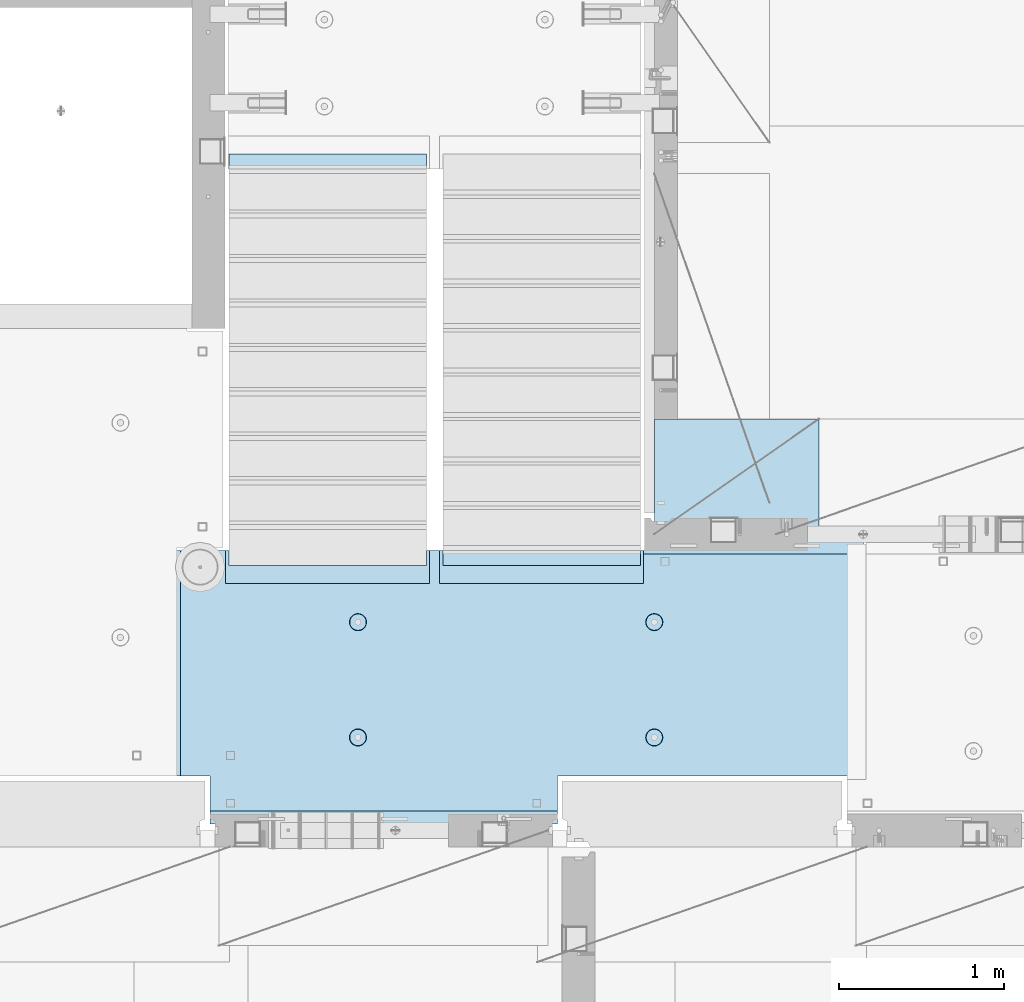
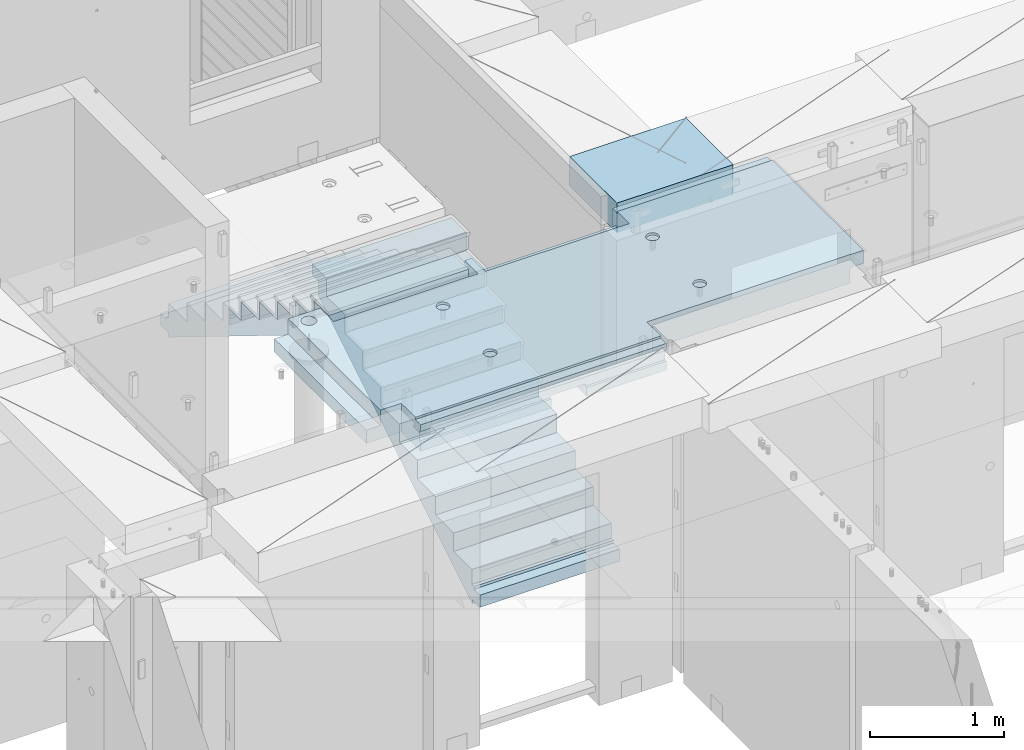
# One storey, part 208 of 350: 3 plates, 1 slab, 4 elements without a shape of their own.
"""IFC2X3 building model written with IfcOpenShell, lengths in millimetres."""

import ifcopenshell
import ifcopenshell.guid

model = None  # the IFC model being written
_history = None  # IfcOwnerHistory: only IFC2X3 demands one
_inside = {}  # id of a spatial element -> (the spatial element, [elements in it])
_under = {}  # id of a project, library or spatial element -> (it, [spatial elements below it])
_declared = {}  # id of a project -> (the project, [libraries it declares])
_typed = {}  # id of a type object -> (the type object, [elements of that type])
_made_of = {}  # id of a material, layer set ... -> (it, [elements and type objects made of it])


def new_model(schema):
    """Start an empty IFC model of exactly this schema.

    Asked for "IFC4X3", IfcOpenShell would pick the latest addendum, in which some entities
    have other attributes; the version numbers below select the first issue.
    IFC2X3 requires an IfcOwnerHistory on every rooted entity: one is made here for all.
    """
    global model, _history
    if schema == "IFC4X3":
        model = ifcopenshell.file(schema_version=(4, 3, 0, 0))
    else:
        model = ifcopenshell.file(schema=schema)
    _inside.clear()
    _under.clear()
    _declared.clear()
    _typed.clear()
    _made_of.clear()
    _history = None
    if model.schema == "IFC2X3":
        org = make("IfcOrganization", Name="unknown")
        user = make(
            "IfcPersonAndOrganization",
            ThePerson=make("IfcPerson", FamilyName="unknown"),
            TheOrganization=org,
        )
        app = make(
            "IfcApplication",
            ApplicationDeveloper=org,
            Version="unknown",
            ApplicationFullName="unknown",
            ApplicationIdentifier="unknown",
        )
        _history = make(
            "IfcOwnerHistory",
            OwningUser=user,
            OwningApplication=app,
            ChangeAction="ADDED",
            CreationDate=0,
        )
    return model


def make(cls, **values):
    """One entity of the class cls with the attributes given. An attribute that is None is left unset."""
    return model.create_entity(
        cls, **{name: value for name, value in values.items() if value is not None}
    )


def rooted(cls, **values):
    """An entity with a GlobalId (a new one), such as an element, a storey or a relation."""
    return make(cls, GlobalId=ifcopenshell.guid.new(), OwnerHistory=_history, **values)


def si_unit(unit_type, name, prefix=None):
    """IfcSIUnit, for example si_unit("LENGTHUNIT", "METRE", prefix="MILLI")."""
    return make("IfcSIUnit", UnitType=unit_type, Prefix=prefix, Name=name)


def assignment(units):
    """IfcUnitAssignment: the units of a project."""
    return None if units is None else make("IfcUnitAssignment", Units=units)


def point(xyz):
    """IfcCartesianPoint."""
    return None if xyz is None else make("IfcCartesianPoint", Coordinates=xyz)


def direction(xyz):
    """IfcDirection."""
    return None if xyz is None else make("IfcDirection", DirectionRatios=xyz)


def frame(location, z_axis=None, x_axis=None):
    """IfcAxis2Placement3D, a coordinate frame: its origin and axes. An axis left out is left unset."""
    return make(
        "IfcAxis2Placement3D",
        Location=point(location),
        Axis=direction(z_axis),
        RefDirection=direction(x_axis),
    )


def origin_with_axes():
    """The frame at (0, 0, 0) with the z axis (0, 0, 1) and the x axis (1, 0, 0) written out."""
    return frame((0.0, 0.0, 0.0), z_axis=(0.0, 0.0, 1.0), x_axis=(1.0, 0.0, 0.0))


def place(relative_to, where):
    """IfcLocalPlacement: puts the frame where relative to a parent placement (None: the world)."""
    return make(
        "IfcLocalPlacement", PlacementRelTo=relative_to, RelativePlacement=where
    )


def context(
    kind, dimensions, precision=None, world=None, true_north=None, identifier=None
):
    """IfcGeometricRepresentationContext, for example the 3D "Model" context."""
    return make(
        "IfcGeometricRepresentationContext",
        ContextIdentifier=identifier,
        ContextType=kind,
        CoordinateSpaceDimension=dimensions,
        Precision=precision,
        WorldCoordinateSystem=world,
        TrueNorth=true_north,
    )


def subcontext(parent, identifier, kind, view, scale=None):
    """IfcGeometricRepresentationSubContext, for example "Body" below "Model"."""
    return make(
        "IfcGeometricRepresentationSubContext",
        ContextIdentifier=identifier,
        ContextType=kind,
        ParentContext=parent,
        TargetScale=scale,
        TargetView=view,
    )


def project(units=None, contexts=None):
    """IfcProject with its units and contexts."""
    return rooted(
        "IfcProject",
        Name="project",
        RepresentationContexts=contexts,
        UnitsInContext=assignment(units),
    )


def spatial(cls, under=None, at=None, **own):
    """A site, building, storey or space (cls), placed at a placement, below another one or the project."""
    s = rooted(cls, ObjectPlacement=at, **own)
    if under is not None:
        _under.setdefault(under.id(), (under, []))[1].append(s)
    return s


def faces_of(points, faces, orient=None, outer=None):
    """IfcFace entities. A face is a list of loops; a loop is a list of indices into points, from 0.

    orient and outer hold one flag for each loop. By default every Orientation is true, the
    first loop of a face is its IfcFaceOuterBound and the others are IfcFaceBound.
    """
    made = []
    for i, loops in enumerate(faces):
        bounds = []
        for j, loop in enumerate(loops):
            is_outer = j == 0 if outer is None else outer[i][j]
            bounds.append(
                make(
                    "IfcFaceOuterBound" if is_outer else "IfcFaceBound",
                    Bound=make("IfcPolyLoop", Polygon=[points[k] for k in loop]),
                    Orientation=True if orient is None else orient[i][j],
                )
            )
        made.append(make("IfcFace", Bounds=bounds))
    return made


def faceted_brep(points, faces, orient=None, outer=None, voids=None):
    """IfcFacetedBrep: a solid bounded by flat faces; with voids (closed shells), ...WithVoids."""
    shared = [point(p) for p in points]
    hull = make("IfcClosedShell", CfsFaces=faces_of(shared, faces, orient, outer))
    if voids is None:
        return make("IfcFacetedBrep", Outer=hull)
    return make(
        "IfcFacetedBrepWithVoids",
        Outer=hull,
        Voids=[
            make(cls, CfsFaces=faces_of(shared, fs, o, b)) for cls, fs, o, b in voids
        ],
    )


def shape(context_of_items, identifier, shape_type, items):
    """IfcShapeRepresentation: the items that make up one representation, for example the "Body"."""
    return make(
        "IfcShapeRepresentation",
        ContextOfItems=context_of_items,
        RepresentationIdentifier=identifier,
        RepresentationType=shape_type,
        Items=items,
    )


def material(Name=None, Category=None):
    """IfcMaterial."""
    return make("IfcMaterial", Name=Name, Category=Category)


def made_of(thing, what):
    """Note that an element or type object is made of a material, layer set ...; save() writes the relation."""
    if what is not None:
        _made_of.setdefault(what.id(), (what, []))[1].append(thing)
    return thing


def type_object(cls, material=None, **own):
    """A type object (cls), such as IfcWallType, which elements share."""
    return made_of(rooted(cls, **own), material)


def element(
    cls,
    number,
    at=None,
    inside=None,
    cuts=None,
    type_object=None,
    material=None,
    context=None,
    identifier="Body",
    shape_type=None,
    held_by="IfcProductDefinitionShape",
    body=None,
    shapes=None,
    **own,
):
    """One element of the class cls, such as IfcWall. Its Tag is "e" and its number.

    at: its placement. inside: the storey or other place that contains it. cuts: it is an
    opening in that element (IfcRelVoidsElement). A single representation is given by context,
    identifier, shape_type and body (its items); several are given by shapes. held_by: the class
    of the entity that holds the representations. save() writes the other relations.
    """
    e = rooted(cls, Tag="e%d" % number, ObjectPlacement=at, **own)
    if body is not None:
        shapes = [shape(context, identifier, shape_type, body)]
    if shapes is not None:
        e.Representation = make(held_by, Representations=shapes)
    if inside is not None:
        _inside.setdefault(inside.id(), (inside, []))[1].append(e)
    if cuts is not None:
        rooted(
            "IfcRelVoidsElement", RelatingBuildingElement=cuts, RelatedOpeningElement=e
        )
    if type_object is not None:
        _typed.setdefault(type_object.id(), (type_object, []))[1].append(e)
    return made_of(e, material)


def aggregate(whole, parts):
    """IfcRelAggregates: a whole, such as a stair, and the parts it consists of."""
    return rooted("IfcRelAggregates", RelatingObject=whole, RelatedObjects=parts)


def save(model, path):
    """Write the relations noted so far, then the file.

    IfcRelAggregates (storeys below a building ...), IfcRelContainedInSpatialStructure (elements
    in a storey), IfcRelDefinesByType, IfcRelAssociatesMaterial and IfcRelDeclares: one each for
    every whole, place, type object, material and project.
    """
    for whole, parts in _under.values():
        aggregate(whole, parts)
    for where, things in _inside.values():
        rooted(
            "IfcRelContainedInSpatialStructure",
            RelatedElements=things,
            RelatingStructure=where,
        )
    for kind, things in _typed.values():
        rooted("IfcRelDefinesByType", RelatedObjects=things, RelatingType=kind)
    for what, things in _made_of.values():
        rooted("IfcRelAssociatesMaterial", RelatedObjects=things, RelatingMaterial=what)
    for by, libraries in _declared.values():
        rooted("IfcRelDeclares", RelatingContext=by, RelatedDefinitions=libraries)
    model.write(path)


model = new_model("IFC2X3")

# Units and contexts
model_context = context("Model", 3, precision=1e-05, world=origin_with_axes())
body_context = subcontext(model_context, "Body", "Model", "MODEL_VIEW")
ifc_project = project(units=[si_unit("LENGTHUNIT", "METRE", prefix="MILLI"), si_unit("AREAUNIT", "SQUARE_METRE"), si_unit("VOLUMEUNIT", "CUBIC_METRE"), si_unit("MASSUNIT", "GRAM", prefix="KILO"), si_unit("TIMEUNIT", "SECOND"), si_unit("PLANEANGLEUNIT", "RADIAN"), si_unit("SOLIDANGLEUNIT", "STERADIAN"), si_unit("THERMODYNAMICTEMPERATUREUNIT", "DEGREE_CELSIUS"), si_unit("LUMINOUSINTENSITYUNIT", "LUMEN")], contexts=[model_context])

# Site, building, storey
site_placement = place(None, origin_with_axes())
site = spatial("IfcSite", under=ifc_project, at=site_placement, CompositionType="ELEMENT")
building_placement = place(site_placement, origin_with_axes())
building = spatial("IfcBuilding", under=site, at=building_placement, CompositionType="ELEMENT")
storey_placement = place(building_placement, origin_with_axes())
storey = spatial("IfcBuildingStorey", under=building, at=storey_placement, Name="2", CompositionType="ELEMENT", Elevation=0.0)

# Assembly, slab
assembly_1_placement = place(storey_placement, origin_with_axes())
assembly_1 = element("IfcElementAssembly", 1, at=assembly_1_placement, inside=storey, AssemblyPlace="NOTDEFINED", PredefinedType="REINFORCEMENT_UNIT")
ifc_material_1 = material(Name="CONCRETE/C25/30")
slab_type = type_object("IfcSlabType", PredefinedType="NOTDEFINED")
slab_placement = place(assembly_1_placement, frame((23540.0159390845, 15510.0026483125, 87620.0), z_axis=(-0.999999999997437, -2.26400000064461e-06, 0.0), x_axis=(-2.2639999995273e-06, 0.999999999997437, 0.0)))
slab = element("IfcSlab", 2, at=slab_placement, type_object=slab_type, material=ifc_material_1, PredefinedType="FLOOR", context=body_context, shape_type="Brep", body=[
    faceted_brep([(-269.991394356101, 30.0, 2845.00213671412), (-79.9935682977648, 30.0, 2845.00213671301), (-79.9942474988402, 30.0, 2545.001661275), (-269.991475956112, 30.0, 2545.00209142873), (-79.9935682977648, 130.0, 2845.00213671301), (-269.991394356102, 50.0011356208415, 2845.00213671412), (-289.993566176285, 50.0011356208415, 2845.00213671423), (-289.993566176285, 130.0, 2845.00213671423), (-79.9942474988402, 130.0, 2545.001661275), (-289.994243058944, 130.0, 2545.00213671499), (-289.994243058944, 50.0011356208415, 2545.00213671499), (-269.991475956114, 50.0011356208415, 2545.00209142873), (250.667816023648, -110.0, 1223.00869116667), (264.606228919523, -110.0, 1230.11066726268), (275.667816023648, -110.0, 1241.1722543668), (282.76979211966, -110.0, 1255.11066726268), (285.216966304903, -110.0, 1270.56151698143), (282.769792119658, -110.0, 1286.01236670018), (275.667816023648, -110.0, 1299.95077959605), (264.606228919525, -110.0, 1311.01236670018), (250.667816023648, -110.0, 1318.11434279619), (235.216966304901, -110.0, 1320.56151698143), (219.766116586154, -110.0, 1318.11434279619), (205.827703690276, -110.0, 1311.01236670018), (194.766116586154, -110.0, 1299.95077959605), (187.664140490142, -110.0, 1286.01236670018), (185.216966304899, -110.0, 1270.56151698143), (187.664140490144, -110.0, 1255.11066726268), (194.766116586154, -110.0, 1241.1722543668), (205.827703690276, -110.0, 1230.11066726268), (219.766116586154, -110.0, 1223.00869116667), (235.216966304901, -110.0, 1220.56151698143), (251.370127374501, -130.0, 1220.84719908418), (235.216966304901, -130.0, 1218.2887897087), (265.942104492917, -130.0, 1228.27199227546), (277.506491010863, -130.0, 1239.83637879341), (284.931284202146, -130.0, 1254.40835591183), (287.489693577627, -130.0, 1270.56151698143), (284.931284202146, -130.0, 1286.71467805103), (277.506491010861, -130.0, 1301.28665516945), (265.942104492917, -130.0, 1312.85104168739), (251.370127374501, -130.0, 1320.27583487867), (235.216966304901, -130.0, 1322.83424425416), (219.063805235301, -130.0, 1320.27583487867), (204.491828116883, -130.0, 1312.85104168739), (192.927441598938, -130.0, 1301.28665516945), (185.502648407655, -130.0, 1286.71467805103), (182.944239032175, -130.0, 1270.56151698143), (185.502648407655, -130.0, 1254.40835591183), (192.92744159894, -130.0, 1239.83637879341), (204.491828116883, -130.0, 1228.27199227546), (219.063805235301, -130.0, 1220.84719908418), (1370.00988769532, 9.99999999994179, 4270.0029296875), (0.00703133410206647, 9.99999999994179, 4270.00341796875), (0.00594789032584231, 9.99999999994179, 4150.00335886026), (1370.00950450419, 9.99999999994179, 4150.0022190173), (1370.00988769532, 130.0, 4270.0029296875), (0.00703133410206647, 130.0, 4270.00341796875), (-289.995788574217, 50.0011356208415, 1860.01696777343), (-269.99166227209, 50.0011356208415, 1860.01689198933), (-289.995788574217, 130.0, 1860.01696777343), (1410.00403637765, -10.0000000000582, 115.00218916441), (-0.000334584017764428, -10.0000000000582, 115.003668258996), (-0.000334584015945438, 130.0, 115.003668258996), (1430.00436377147, 130.0, 115.002168181909), (1430.00283514406, 50.0011356437899, 115.002168184747), (1410.00403637764, 50.0011356208415, 115.002189163421), (1430.00659179688, 130.0, 1330.01220703125), (1370.00036621094, 130.0, 1330.01281738281), (1370.00036621094, -110.000000000073, 1330.01281738281), (1430.00659179688, -110.000000000073, 1330.01220703125), (1430.00656714066, -110.000000000073, 1.33804860524833e-08), (1350.00656713971, -110.000000000073, -1.09139364212751e-10), (1350.00656713971, -130.0, -9.31322574615479e-10), (0.0, -130.0, -3.63797880709171e-12), (0.0, -10.0, 0.0), (1410.00416932017, -10.0000000000582, 1.69893610291183e-09), (1410.00416932017, -49.9988643791585, 5.89352566748858e-10), (1430.00416932019, -49.9988643791585, 2.83398549072444e-09), (1430.00277003324, 50.0011356208415, 1270.01537795496), (1430.00277003324, -49.9988643791585, 1270.01537795496), (1410.00277003325, 50.0011356208415, 1270.01535591496), (1410.00277003325, -49.9988643791585, 1270.01535591496), (-0.00148380931932479, -130.0, 510.016937255856), (-0.00148380931932479, 130.0, 510.016937255856), (0.00156440050341189, -130.0, 1860.01586914062), (0.00156440050341189, 130.0, 1860.01586914062), (-209.991713751984, -130.000000000058, 1860.01666468411), (-209.996345203012, -130.0, 3970.01713194715), (-209.996345203012, -110.000000000058, 3970.01713194715), (-209.991713751984, -110.000000000058, 1860.01666468411), (-289.991027832028, -110.000000000058, 3970.01733398437), (-289.995788574217, -110.000000000058, 1860.01696777343), (-289.991027832028, -49.9988643791585, 3970.01733398437), (-289.995788574217, -49.9988643791585, 1860.01696777343), (-269.99166227209, -49.9988643791585, 1860.01689198933), (-289.991027832028, 50.0011356208415, 3970.01733398437), (-289.991027832028, 130.0, 3970.01733398437), (-269.991088351981, 50.0011356208415, 3970.01728347186), (-269.991088351981, -49.9988643791585, 3970.01728347186), (0.00432284502676339, -130.0, 3970.0166015625), (0.00432284502676339, 130.0, 3970.0166015625), (0.00594789032584231, -130.0, 4150.00335886026), (1370.00950450419, -130.000000000058, 4150.0022190173), (1370.00860847198, 9.99639270307671, 3875.01157736929), (1170.00318277859, 9.99639270307671, 3875.01203018158), (1170.00037541444, 9.99639270307671, 2635.01019913007), (1370.00459258838, 9.99639270307671, 2635.00974632052), (1370.00860847197, -130.000000000058, 3875.01157736929), (1170.00318277859, -130.000000000029, 3875.01203018158), (1170.00037541444, -130.000000000029, 2635.01019913007), (1370.00459258838, -130.000000000029, 2635.00974632052), (1370.00439827764, -130.000000000029, 2575.01157737549), (1170.00023957859, -130.000000000029, 2575.01203018491), (1170.00023957859, 9.99639270307671, 2575.01203018491), (1370.00439827764, 9.99639270307671, 2575.01157737549), (1169.99743221444, -130.000000000029, 1335.0101991334), (1169.99743221444, 9.99639270307671, 1335.0101991334), (1370.00038239405, 9.99639270307671, 1335.00974632672), (1370.00038239405, -110.000000000073, 1335.00974632672), (1350.00004294686, -110.000000000073, 1335.00979160748), (1350.00004294686, -130.000000000073, 1335.00979160748), (920.332855772751, -110.0, 1318.11282667454), (906.394410719273, -110.0, 1311.01091369173), (895.332773528397, -110.0, 1299.94937667459), (888.230734319324, -110.0, 1286.01099593661), (885.78349017266, -110.0, 1270.56015729882), (888.230594396427, -110.0, 1255.10929649942), (895.332507379233, -110.0, 1241.17085144594), (906.394044396377, -110.0, 1230.10921425507), (920.332425134358, -110.0, 1223.00717504599), (935.783263772144, -110.0, 1220.55993089933), (951.234124571543, -110.0, 1223.0070351231), (965.172569625021, -110.0, 1230.10894810591), (976.234206815898, -110.0, 1241.17048512305), (983.33624602497, -110.0, 1255.10886586103), (985.783490171634, -110.0, 1270.55970449882), (983.336385947867, -110.0, 1286.01056529821), (976.234472965061, -110.0, 1299.94901035169), (965.172935947918, -110.0, 1311.01064754257), (951.234555209936, -110.0, 1318.11268675164), (935.783716572147, -110.0, 1320.5599308983), (951.936426135147, -130.0, 1220.84553986057), (935.783253481237, -130.0, 1218.28720362663), (966.508436872882, -130.0, 1228.27026706986), (978.072875754253, -130.0, 1239.83460122415), (985.497734927369, -130.0, 1254.40654472295), (988.05621744434, -130.0, 1270.55969420791), (985.497881210395, -130.0, 1286.71286686182), (978.073154001104, -130.0, 1301.28487759955), (966.508819846818, -130.0, 1312.84931648092), (951.936876348012, -130.0, 1320.27417565404), (935.783726863054, -130.0, 1322.83265817101), (919.630554209147, -130.0, 1320.27432193707), (905.058543471412, -130.0, 1312.84959472777), (893.494104590041, -130.0, 1301.28526057349), (886.069245416922, -130.0, 1286.71331707469), (883.510762899954, -130.0, 1270.56016758973), (886.069099133892, -130.0, 1254.40699493582), (893.49382634319, -130.0, 1239.83498419809), (905.058160497476, -130.0, 1228.27054531671), (919.630103996282, -130.0, 1220.84568614359), (920.336931380272, -110.0, 3118.29282666992), (906.398486326791, -110.0, 3111.19091368712), (895.336849135918, -110.0, 3100.12937666997), (888.234809926846, -110.0, 3086.19099593199), (885.787565780181, -110.0, 3070.7401572942), (888.234670003949, -110.0, 3055.28929649481), (895.336582986754, -110.0, 3041.35085144133), (906.398120003898, -110.0, 3030.28921425045), (920.33650074188, -110.0, 3023.18717504138), (935.787339379665, -110.0, 3020.73993089472), (951.238200179065, -110.0, 3023.18703511849), (965.176645232543, -110.0, 3030.28894810129), (976.238282423419, -110.0, 3041.35048511844), (983.340321632491, -110.0, 3055.28886585642), (985.787565779156, -110.0, 3070.7397044942), (983.340461555388, -110.0, 3086.1905652936), (976.238548572583, -110.0, 3100.12901034708), (965.177011555439, -110.0, 3111.19064753796), (951.238630817454, -110.0, 3118.29268674703), (935.787792179664, -110.0, 3120.73993089369), (951.940501742669, -130.000000000015, 3021.02553985595), (935.787329088758, -130.000000000015, 3018.46720362201), (966.512512480404, -130.000000000015, 3028.45026706525), (978.076951361778, -130.000000000015, 3040.01460121954), (985.50181053489, -130.000000000015, 3054.58654471834), (988.060293051862, -130.000000000015, 3070.73969420329), (985.501956817916, -130.000000000015, 3086.89286685721), (978.077229608625, -130.000000000015, 3101.46487759494), (966.51289545434, -130.000000000015, 3113.02931647631), (951.940951955534, -130.000000000015, 3120.45417564943), (935.787802470575, -130.000000000015, 3123.01265816639), (919.634629816665, -130.000000000015, 3120.45432193246), (905.062619078933, -130.000000000015, 3113.02959472316), (893.498180197559, -130.000000000015, 3101.46526056888), (886.07332102444, -130.000000000015, 3086.89331707007), (883.514838507475, -130.000000000015, 3070.74016758511), (886.073174741414, -130.000000000015, 3054.5869949312), (893.497901950712, -130.000000000015, 3040.01498419347), (905.062236104997, -130.000000000015, 3028.4505453121), (919.634179603803, -130.000000000015, 3021.02568613898), (250.671891631169, -110.0, 3023.18869116206), (264.610304527045, -110.0, 3030.29066725807), (275.671891631167, -110.0, 3041.35225436219), (282.773867727179, -110.0, 3055.29066725806), (285.221041912424, -110.0, 3070.74151697681), (282.773867727179, -110.0, 3086.19236669556), (275.671891631169, -110.0, 3100.13077959144), (264.610304527047, -110.0, 3111.19236669556), (250.671891631169, -110.0, 3118.29434279157), (235.221041912422, -110.0, 3120.74151697681), (219.770192193675, -110.0, 3118.29434279157), (205.831779297798, -110.0, 3111.19236669556), (194.770192193675, -110.0, 3100.13077959144), (187.668216097663, -110.0, 3086.19236669556), (185.22104191242, -110.0, 3070.74151697681), (187.668216097663, -110.0, 3055.29066725806), (194.770192193673, -110.0, 3041.35225436219), (205.831779297798, -110.0, 3030.29066725807), (219.770192193673, -110.0, 3023.18869116206), (235.221041912422, -110.0, 3020.74151697681), (251.374202982022, -130.0, 3021.02719907957), (235.221041912422, -130.0, 3018.46878970409), (265.946180100438, -130.0, 3028.45199227085), (277.510566618384, -130.0, 3040.0163787888), (284.935359809668, -130.0, 3054.58835590722), (287.493769185148, -130.0, 3070.74151697681), (284.935359809668, -130.0, 3086.89467804641), (277.510566618383, -130.0, 3101.46665516483), (265.946180100438, -130.0, 3113.03104168278), (251.374202982022, -130.0, 3120.45583487406), (235.22104191242, -130.0, 3123.01424424954), (219.067880842822, -130.0, 3120.45583487406), (204.495903724404, -130.0, 3113.03104168278), (192.93151720646, -130.0, 3101.46665516483), (185.506724015177, -130.0, 3086.89467804641), (182.948314639694, -130.0, 3070.74151697681), (185.506724015177, -130.0, 3054.58835590722), (192.93151720646, -130.0, 3040.0163787888), (204.495903724404, -130.0, 3028.45199227085), (219.06788084282, -130.0, 3021.02719907957), (1234.74413944682, -130.000000000029, 3981.4733287671), (1221.47026497402, -130.000000000029, 3994.74726334413), (1212.94793152671, -130.000000000029, 4011.47337811379), (1210.0113644813, -130.000000000029, 4030.01440442472), (1212.94801548044, -130.000000000029, 4048.55541743869), (1221.47042466352, -130.000000000029, 4065.28149361904), (1234.74435924055, -130.000000000029, 4078.55536809184), (1251.47047401021, -130.000000000029, 4087.07770153915), (1270.01150032114, -130.000000000029, 4090.01426858456), (1288.55251333511, -130.000000000029, 4087.07761758541), (1305.27858951547, -130.000000000029, 4078.55520840234), (1318.55246398826, -130.000000000029, 4065.28127382531), (1327.07479743557, -130.000000000029, 4048.55515905565), (1330.01136448099, -130.000000000029, 4030.01413274472), (1327.07471348184, -130.000000000029, 4011.47311973075), (1318.55230429877, -130.000000000029, 3994.74704355039), (1305.27836972173, -130.000000000029, 3981.4731690776), (1288.55225495208, -130.000000000029, 3972.95083563029), (1270.01122864114, -130.000000000029, 3970.01426858487), (1251.47021562717, -130.000000000029, 3972.95091958403), (1305.27836972173, 130.0, 3981.4731690776), (1288.55225495208, 130.0, 3972.95083563029), (1318.55230429877, 130.0, 3994.74704355039), (1327.07471348184, 130.0, 4011.47311973075), (1330.01136448099, 130.0, 4030.01413274472), (1327.07479743557, 130.0, 4048.55515905565), (1318.55246398826, 130.0, 4065.28127382531), (1305.27858951547, 130.0, 4078.55520840234), (1288.55251333511, 130.0, 4087.07761758541), (1270.01150032114, 130.0, 4090.01426858456), (1251.47047401021, 130.0, 4087.07770153915), (1234.74435924055, 130.0, 4078.55536809184), (1221.47042466352, 130.0, 4065.28149361904), (1212.94801548044, 130.0, 4048.55541743869), (1210.0113644813, 130.0, 4030.01440442472), (1212.94793152671, 130.0, 4011.47337811379), (1221.47026497402, 130.0, 3994.74726334413), (1234.74413944682, 130.0, 3981.4733287671), (1251.47021562717, 130.0, 3972.95091958403), (1270.01122864114, 130.0, 3970.01426858487)], [[[0, 1, 2, 3]], [[4, 1, 0, 5, 6, 7]], [[8, 2, 1, 4]], [[9, 10, 11, 3, 2, 8]], [[12, 13, 14, 15, 16, 17, 18, 19, 20, 21, 22, 23, 24, 25, 26, 27, 28, 29, 30, 31]], [[32, 12, 31, 33]], [[34, 13, 12, 32]], [[35, 14, 13, 34]], [[36, 15, 14, 35]], [[37, 16, 15, 36]], [[38, 17, 16, 37]], [[39, 18, 17, 38]], [[40, 19, 18, 39]], [[41, 20, 19, 40]], [[42, 21, 20, 41]], [[43, 22, 21, 42]], [[44, 23, 22, 43]], [[45, 24, 23, 44]], [[46, 25, 24, 45]], [[47, 26, 25, 46]], [[48, 27, 26, 47]], [[49, 28, 27, 48]], [[50, 29, 28, 49]], [[51, 30, 29, 50]], [[33, 31, 30, 51]], [[52, 53, 54, 55]], [[56, 57, 53, 52]], [[58, 59, 11, 10]], [[60, 58, 10, 9]], [[61, 62, 63, 64, 65, 66]], [[67, 68, 69, 70]], [[71, 72, 73, 74, 75, 76, 77, 78]], [[79, 65, 64, 67, 70, 71, 78, 80]], [[65, 79, 81, 66]], [[80, 82, 81, 79]], [[78, 77, 82, 80]], [[76, 61, 66, 81, 82, 77]], [[75, 62, 61, 76]], [[74, 83, 84, 63, 62, 75]], [[83, 85, 86, 84]], [[87, 88, 89, 90]], [[90, 89, 91, 92]], [[92, 91, 93, 94]], [[58, 60, 86, 85, 87, 90, 92, 94, 95, 59]], [[96, 97, 7, 6]], [[98, 96, 6, 5]], [[59, 95, 99, 98, 5, 0, 3, 11]], [[94, 93, 99, 95]], [[91, 89, 88, 100, 101, 97, 96, 98, 99, 93]], [[53, 57, 101, 100, 102, 54]], [[103, 55, 54, 102]], [[104, 105, 106, 107]], [[108, 109, 105, 104]], [[110, 106, 105, 109]], [[111, 107, 106, 110]], [[112, 113, 114, 115]], [[116, 117, 114, 113]], [[115, 114, 117, 118]], [[69, 68, 56, 52, 55, 103, 108, 104, 107, 111, 112, 115, 118, 119]], [[72, 71, 70, 69, 119, 120]], [[73, 72, 120, 121]], [[119, 118, 117, 116, 121, 120]], [[122, 123, 124, 125, 126, 127, 128, 129, 130, 131, 132, 133, 134, 135, 136, 137, 138, 139, 140, 141]], [[142, 132, 131, 143]], [[144, 133, 132, 142]], [[145, 134, 133, 144]], [[146, 135, 134, 145]], [[147, 136, 135, 146]], [[148, 137, 136, 147]], [[149, 138, 137, 148]], [[150, 139, 138, 149]], [[151, 140, 139, 150]], [[152, 141, 140, 151]], [[153, 122, 141, 152]], [[154, 123, 122, 153]], [[155, 124, 123, 154]], [[156, 125, 124, 155]], [[157, 126, 125, 156]], [[158, 127, 126, 157]], [[159, 128, 127, 158]], [[160, 129, 128, 159]], [[161, 130, 129, 160]], [[143, 131, 130, 161]], [[162, 163, 164, 165, 166, 167, 168, 169, 170, 171, 172, 173, 174, 175, 176, 177, 178, 179, 180, 181]], [[182, 172, 171, 183]], [[184, 173, 172, 182]], [[185, 174, 173, 184]], [[186, 175, 174, 185]], [[187, 176, 175, 186]], [[188, 177, 176, 187]], [[189, 178, 177, 188]], [[190, 179, 178, 189]], [[191, 180, 179, 190]], [[192, 181, 180, 191]], [[193, 162, 181, 192]], [[194, 163, 162, 193]], [[195, 164, 163, 194]], [[196, 165, 164, 195]], [[197, 166, 165, 196]], [[198, 167, 166, 197]], [[199, 168, 167, 198]], [[200, 169, 168, 199]], [[201, 170, 169, 200]], [[183, 171, 170, 201]], [[202, 203, 204, 205, 206, 207, 208, 209, 210, 211, 212, 213, 214, 215, 216, 217, 218, 219, 220, 221]], [[222, 202, 221, 223]], [[224, 203, 202, 222]], [[225, 204, 203, 224]], [[226, 205, 204, 225]], [[227, 206, 205, 226]], [[228, 207, 206, 227]], [[229, 208, 207, 228]], [[230, 209, 208, 229]], [[231, 210, 209, 230]], [[232, 211, 210, 231]], [[233, 212, 211, 232]], [[234, 213, 212, 233]], [[235, 214, 213, 234]], [[236, 215, 214, 235]], [[237, 216, 215, 236]], [[238, 217, 216, 237]], [[239, 218, 217, 238]], [[240, 219, 218, 239]], [[241, 220, 219, 240]], [[223, 221, 220, 241]], [[113, 112, 111, 110, 109, 108, 103, 102, 100, 88, 87, 85, 83, 74, 73, 121, 116], [240, 239, 238, 237, 236, 235, 234, 233, 232, 231, 230, 229, 228, 227, 226, 225, 224, 222, 223, 241], [200, 199, 198, 197, 196, 195, 194, 193, 192, 191, 190, 189, 188, 187, 186, 185, 184, 182, 183, 201], [160, 159, 158, 157, 156, 155, 154, 153, 152, 151, 150, 149, 148, 147, 146, 145, 144, 142, 143, 161], [50, 49, 48, 47, 46, 45, 44, 43, 42, 41, 40, 39, 38, 37, 36, 35, 34, 32, 33, 51], [242, 243, 244, 245, 246, 247, 248, 249, 250, 251, 252, 253, 254, 255, 256, 257, 258, 259, 260, 261]], [[258, 262, 263, 259]], [[257, 264, 262, 258]], [[256, 265, 264, 257]], [[255, 266, 265, 256]], [[254, 267, 266, 255]], [[253, 268, 267, 254]], [[252, 269, 268, 253]], [[251, 270, 269, 252]], [[250, 271, 270, 251]], [[249, 272, 271, 250]], [[248, 273, 272, 249]], [[247, 274, 273, 248]], [[246, 275, 274, 247]], [[245, 276, 275, 246]], [[244, 277, 276, 245]], [[243, 278, 277, 244]], [[242, 279, 278, 243]], [[261, 280, 279, 242]], [[260, 281, 280, 261]], [[259, 263, 281, 260]], [[7, 97, 101, 57, 56, 68, 67, 64, 63, 84, 86, 60, 9, 8, 4], [262, 264, 265, 266, 267, 268, 269, 270, 271, 272, 273, 274, 275, 276, 277, 278, 279, 280, 281, 263]]]),
])
aggregate(assembly_1, [slab])

# Assembly, plate
assembly_2_placement = place(storey_placement, origin_with_axes())
assembly_2 = element("IfcElementAssembly", 3, at=assembly_2_placement, inside=storey, Name="E9", AssemblyPlace="NOTDEFINED", PredefinedType="NOTDEFINED")
ifc_material_2 = material(Name="Undefined/C32/40")
plate_type_1 = type_object("IfcPlateType", PredefinedType="NOTDEFINED")
plate_1_placement = place(assembly_2_placement, frame((20285.0002457424, 19199.9998138874, 86260.0), z_axis=(0.0, -1.0, 0.0), x_axis=(0.0, 0.0, -1.0)))
plate_1 = element("IfcPlate", 4, at=plate_1_placement, type_object=plate_type_1, material=ifc_material_2, Name="E9", context=body_context, shape_type="Brep", body=[
    faceted_brep([(0.0, -600.0, 0.0), (0.0, -600.0, 30.0), (0.0, 600.0, 30.0), (0.0, 600.0, 0.0), (-136.699996948242, -600.0, 30.0), (-136.699996948242, 600.0, 30.0), (-136.699996948242, -600.0, 300.0), (-136.699996948242, 600.0, 300.0), (-303.399993896484, -600.0, 300.0), (-303.399993896484, 600.0, 300.0), (-303.399993896484, -600.0, 570.0), (-303.399993896484, 600.0, 570.0), (-470.100006103516, -600.0, 570.0), (-470.100006103516, 600.0, 570.0), (-470.100006103516, -600.0, 840.0), (-470.100006103516, 600.0, 840.0), (-636.799987792969, -600.0, 840.0), (-636.799987792969, 600.0, 840.0), (-636.799987792969, -600.0, 1110.0), (-636.799987792969, 600.0, 1110.0), (-803.5, -600.0, 1110.0), (-803.5, 600.0, 1110.0), (-803.5, -600.0, 1380.0), (-803.5, 600.0, 1380.0), (-970.200012207031, -600.0, 1380.0), (-970.200012207031, 600.0, 1380.0), (-970.200012207031, -600.0, 1650.0), (-970.200012207031, 600.0, 1650.0), (-1136.90002441406, -600.0, 1650.0), (-1136.90002441406, 600.0, 1650.0), (-1136.90002441406, -600.0, 1920.0), (-1136.90002441406, 600.0, 1920.0), (-1303.59997558594, -600.0, 1920.0), (-1303.59997558594, 600.0, 1920.0), (-1303.59997558594, -600.0, 2190.0), (-1303.59997558594, 600.0, 2190.0), (-1470.30004882813, -600.0, 2190.0), (-1470.30004882813, 600.0, 2190.0), (-1470.30004882813, -600.0, 2410.0), (-1470.30004882813, 600.0, 2410.0), (-1370.30004882813, -600.0, 2410.0), (-1370.30004882813, 600.0, 2410.0), (-1370.30004882813, -600.0, 2310.0), (-1370.30004882813, 600.0, 2310.0), (-1236.65991210938, -600.0, 2310.0), (-1236.65991210938, 600.0, 2310.0), (170.0, -600.0, 31.6665592193604), (170.0, 600.0, 31.6665592193604), (170.0, -600.0, 20.0), (170.0, 600.0, 20.0), (135.0, -600.0, 20.0), (135.0, 600.0, 20.0), (135.0, -600.0, -90.0), (135.0, 600.0, -90.0), (25.0, -600.0, -90.0), (25.0, 600.0, -90.0), (25.0, -600.0, 0.0), (25.0, 600.0, 0.0)], [[[0, 1, 2, 3]], [[1, 4, 5, 2]], [[4, 6, 7, 5]], [[6, 8, 9, 7]], [[8, 10, 11, 9]], [[10, 12, 13, 11]], [[12, 14, 15, 13]], [[14, 16, 17, 15]], [[16, 18, 19, 17]], [[18, 20, 21, 19]], [[20, 22, 23, 21]], [[22, 24, 25, 23]], [[24, 26, 27, 25]], [[26, 28, 29, 27]], [[28, 30, 31, 29]], [[30, 32, 33, 31]], [[32, 34, 35, 33]], [[34, 36, 37, 35]], [[36, 38, 39, 37]], [[38, 40, 41, 39]], [[40, 42, 43, 41]], [[42, 44, 45, 43]], [[44, 46, 47, 45]], [[46, 48, 49, 47]], [[48, 50, 51, 49]], [[50, 52, 53, 51]], [[52, 54, 55, 53]], [[54, 56, 57, 55]], [[56, 0, 3, 57]], [[5, 7, 9, 11, 13, 15, 17, 19, 21, 23, 25, 27, 29, 31, 33, 35, 37, 39, 41, 43, 45, 47, 49, 51, 53, 55, 57, 3, 2]], [[56, 54, 52, 50, 48, 46, 44, 42, 40, 38, 36, 34, 32, 30, 28, 26, 24, 22, 20, 18, 16, 14, 12, 10, 8, 6, 4, 1, 0]]]),
])
aggregate(assembly_2, [plate_1])

assembly_3_placement = place(storey_placement, origin_with_axes())
assembly_3 = element("IfcElementAssembly", 5, at=assembly_3_placement, inside=storey, Name="E9", AssemblyPlace="NOTDEFINED", PredefinedType="NOTDEFINED")
plate_2_placement = place(assembly_3_placement, frame((21585.002175553, 16880.001025346, 84759.7036072969), z_axis=(0.0, 1.0, 0.0), x_axis=(0.0, 0.0, -1.0)))
plate_2 = element("IfcPlate", 6, at=plate_2_placement, type_object=plate_type_1, material=ifc_material_2, Name="E9", context=body_context, shape_type="Brep", body=[
    faceted_brep([(0.0, -600.0, 0.0), (0.0, -600.0, 30.0), (0.0, 600.0, 30.0), (0.0, 600.0, 0.0), (-136.699996948242, -600.0, 30.0), (-136.699996948242, 600.0, 30.0), (-136.699996948242, -600.0, 300.0), (-136.699996948242, 600.0, 300.0), (-303.399993896484, -600.0, 300.0), (-303.399993896484, 600.0, 300.0), (-303.399993896484, -600.0, 570.0), (-303.399993896484, 600.0, 570.0), (-470.100006103516, -600.0, 570.0), (-470.100006103516, 600.0, 570.0), (-470.100006103516, -600.0, 840.0), (-470.100006103516, 600.0, 840.0), (-636.799987792969, -600.0, 840.0), (-636.799987792969, 600.0, 840.0), (-636.799987792969, -600.0, 1110.0), (-636.799987792969, 600.0, 1110.0), (-803.5, -600.0, 1110.0), (-803.5, 600.0, 1110.0), (-803.5, -600.0, 1380.0), (-803.5, 600.0, 1380.0), (-970.200012207031, -600.0, 1380.0), (-970.200012207031, 600.0, 1380.0), (-970.200012207031, -600.0, 1650.0), (-970.200012207031, 600.0, 1650.0), (-1136.90002441406, -600.0, 1650.0), (-1136.90002441406, 600.0, 1650.0), (-1136.90002441406, -600.0, 1920.0), (-1136.90002441406, 600.0, 1920.0), (-1303.59997558594, -600.0, 1920.0), (-1303.59997558594, 600.0, 1920.0), (-1303.59997558594, -600.0, 2190.0), (-1303.59997558594, 600.0, 2190.0), (-1470.30004882813, -600.0, 2190.0), (-1470.30004882813, 600.0, 2190.0), (-1470.30004882813, -600.0, 2410.0), (-1470.30004882813, 600.0, 2410.0), (-1370.30004882813, -600.0, 2410.0), (-1370.30004882813, 600.0, 2410.0), (-1370.30004882813, -600.0, 2310.0), (-1370.30004882813, 600.0, 2310.0), (-1236.65991210938, -600.0, 2310.0), (-1236.65991210938, 600.0, 2310.0), (170.0, -600.0, 31.6665592193604), (170.0, 600.0, 31.6665592193604), (170.0, -600.0, 20.0), (170.0, 600.0, 20.0), (135.0, -600.0, 20.0), (135.0, 600.0, 20.0), (135.0, -600.0, -90.0), (135.0, 600.0, -90.0), (25.0, -600.0, -90.0), (25.0, 600.0, -90.0), (25.0, -600.0, 0.0), (25.0, 600.0, 0.0)], [[[0, 1, 2, 3]], [[1, 4, 5, 2]], [[4, 6, 7, 5]], [[6, 8, 9, 7]], [[8, 10, 11, 9]], [[10, 12, 13, 11]], [[12, 14, 15, 13]], [[14, 16, 17, 15]], [[16, 18, 19, 17]], [[18, 20, 21, 19]], [[20, 22, 23, 21]], [[22, 24, 25, 23]], [[24, 26, 27, 25]], [[26, 28, 29, 27]], [[28, 30, 31, 29]], [[30, 32, 33, 31]], [[32, 34, 35, 33]], [[34, 36, 37, 35]], [[36, 38, 39, 37]], [[38, 40, 41, 39]], [[40, 42, 43, 41]], [[42, 44, 45, 43]], [[44, 46, 47, 45]], [[46, 48, 49, 47]], [[48, 50, 51, 49]], [[50, 52, 53, 51]], [[52, 54, 55, 53]], [[54, 56, 57, 55]], [[56, 0, 3, 57]], [[5, 7, 9, 11, 13, 15, 17, 19, 21, 23, 25, 27, 29, 31, 33, 35, 37, 39, 41, 43, 45, 47, 49, 51, 53, 55, 57, 3, 2]], [[56, 54, 52, 50, 48, 46, 44, 42, 40, 38, 36, 34, 32, 30, 28, 26, 24, 22, 20, 18, 16, 14, 12, 10, 8, 6, 4, 1, 0]]]),
])
aggregate(assembly_3, [plate_2])

assembly_4_placement = place(storey_placement, origin_with_axes())
assembly_4 = element("IfcElementAssembly", 7, at=assembly_4_placement, inside=storey, Name="Steel Assembly", AssemblyPlace="NOTDEFINED", PredefinedType="NOTDEFINED")
ifc_material_3 = material()
plate_type_2 = type_object("IfcPlateType", PredefinedType="NOTDEFINED")
plate_3_placement = place(assembly_4_placement, frame((22270.0, 16979.9999999293, 87595.3), z_axis=(0.0, 1.0, 0.0), x_axis=(1.0, 0.0, 0.0)))
plate_3 = element("IfcPlate", 8, at=plate_3_placement, type_object=plate_type_2, material=ifc_material_3, Name="RE1_1/2", context=body_context, shape_type="Brep", body=[
    faceted_brep([(1.81898940354586e-12, -135.0, 1.81898940354586e-12), (0.0, -135.0, 699.999999999996), (0.0, 135.0, 699.999999999996), (1.81898940354586e-12, 135.0, 1.81898940354586e-12), (999.99951171875, -135.0, 700.0), (999.99951171875, 135.0, 700.0), (1000.0, -135.0, 0.0), (1000.0, 135.0, 0.0)], [[[0, 1, 2, 3]], [[1, 4, 5, 2]], [[4, 6, 7, 5]], [[6, 0, 3, 7]], [[5, 7, 3, 2]], [[6, 4, 1, 0]]]),
])
aggregate(assembly_4, [plate_3])

save(model, "model.ifc")
